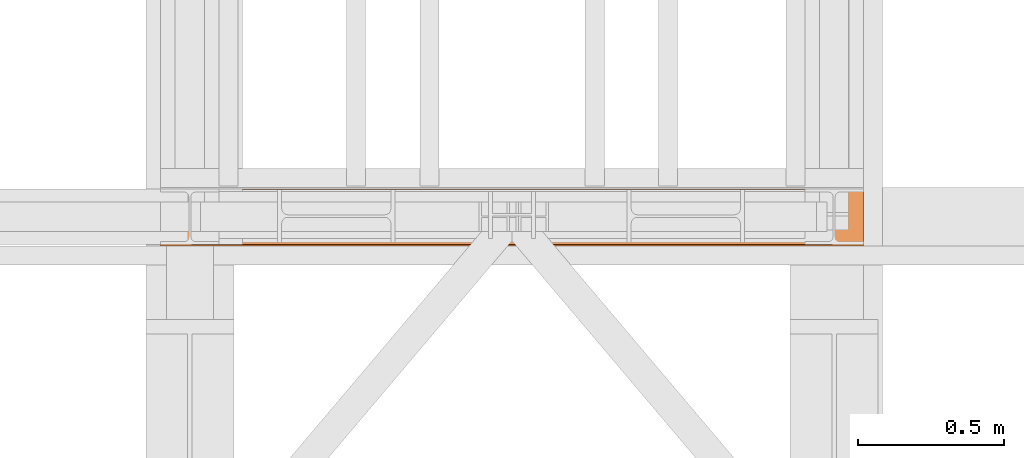
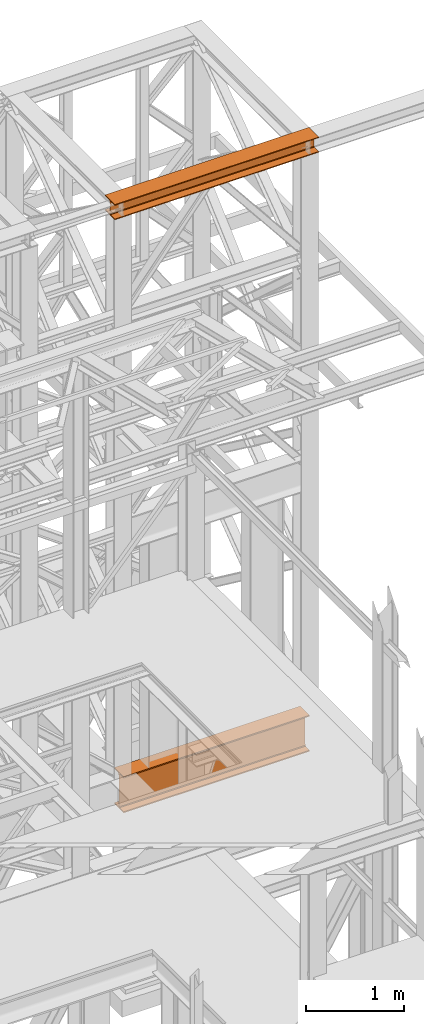
# One storey, part 176 of 208: 2 proxies.
"""IFC2X3 building model written with IfcOpenShell, lengths in millimetres."""

import ifcopenshell
import ifcopenshell.guid

model = None  # the IFC model being written
_history = None  # IfcOwnerHistory: only IFC2X3 demands one
_inside = {}  # id of a spatial element -> (the spatial element, [elements in it])
_under = {}  # id of a project, library or spatial element -> (it, [spatial elements below it])
_declared = {}  # id of a project -> (the project, [libraries it declares])
_typed = {}  # id of a type object -> (the type object, [elements of that type])
_made_of = {}  # id of a material, layer set ... -> (it, [elements and type objects made of it])


def new_model(schema):
    """Start an empty IFC model of exactly this schema.

    Asked for "IFC4X3", IfcOpenShell would pick the latest addendum, in which some entities
    have other attributes; the version numbers below select the first issue.
    IFC2X3 requires an IfcOwnerHistory on every rooted entity: one is made here for all.
    """
    global model, _history
    if schema == "IFC4X3":
        model = ifcopenshell.file(schema_version=(4, 3, 0, 0))
    else:
        model = ifcopenshell.file(schema=schema)
    _inside.clear()
    _under.clear()
    _declared.clear()
    _typed.clear()
    _made_of.clear()
    _history = None
    if model.schema == "IFC2X3":
        org = make("IfcOrganization", Name="unknown")
        user = make(
            "IfcPersonAndOrganization",
            ThePerson=make("IfcPerson", FamilyName="unknown"),
            TheOrganization=org,
        )
        app = make(
            "IfcApplication",
            ApplicationDeveloper=org,
            Version="unknown",
            ApplicationFullName="unknown",
            ApplicationIdentifier="unknown",
        )
        _history = make(
            "IfcOwnerHistory",
            OwningUser=user,
            OwningApplication=app,
            ChangeAction="ADDED",
            CreationDate=0,
        )
    return model


def make(cls, **values):
    """One entity of the class cls with the attributes given. An attribute that is None is left unset."""
    return model.create_entity(
        cls, **{name: value for name, value in values.items() if value is not None}
    )


def entity(cls, *values):
    """Any entity or typed value of the class cls, its attributes in the order of the schema. None: left unset."""
    e = model.create_entity(cls)
    for i, value in enumerate(values):
        if value is not None:
            e[i] = value
    return e


def rooted(cls, **values):
    """An entity with a GlobalId (a new one), such as an element, a storey or a relation."""
    return make(cls, GlobalId=ifcopenshell.guid.new(), OwnerHistory=_history, **values)


def si_unit(unit_type, name, prefix=None):
    """IfcSIUnit, for example si_unit("LENGTHUNIT", "METRE", prefix="MILLI")."""
    return make("IfcSIUnit", UnitType=unit_type, Prefix=prefix, Name=name)


def converted_unit(unit_type, name, factor, base, dimensions=None, offset=None):
    """IfcConversionBasedUnit, such as the inch: factor (a typed value) times the base unit."""
    return make(
        "IfcConversionBasedUnit"
        if offset is None
        else "IfcConversionBasedUnitWithOffset",
        ConversionOffset=offset,
        Dimensions=None
        if dimensions is None
        else entity("IfcDimensionalExponents", *dimensions),
        UnitType=unit_type,
        Name=name,
        ConversionFactor=make(
            "IfcMeasureWithUnit", ValueComponent=factor, UnitComponent=base
        ),
    )


def assignment(units):
    """IfcUnitAssignment: the units of a project."""
    return None if units is None else make("IfcUnitAssignment", Units=units)


def point(xyz):
    """IfcCartesianPoint."""
    return None if xyz is None else make("IfcCartesianPoint", Coordinates=xyz)


def direction(xyz):
    """IfcDirection."""
    return None if xyz is None else make("IfcDirection", DirectionRatios=xyz)


def frame(location, z_axis=None, x_axis=None):
    """IfcAxis2Placement3D, a coordinate frame: its origin and axes. An axis left out is left unset."""
    return make(
        "IfcAxis2Placement3D",
        Location=point(location),
        Axis=direction(z_axis),
        RefDirection=direction(x_axis),
    )


def origin():
    """The frame at (0, 0, 0) with its axes left unset."""
    return frame((0.0, 0.0, 0.0))


def origin_with_axes():
    """The frame at (0, 0, 0) with the z axis (0, 0, 1) and the x axis (1, 0, 0) written out."""
    return frame((0.0, 0.0, 0.0), z_axis=(0.0, 0.0, 1.0), x_axis=(1.0, 0.0, 0.0))


def place(relative_to, where):
    """IfcLocalPlacement: puts the frame where relative to a parent placement (None: the world)."""
    return make(
        "IfcLocalPlacement", PlacementRelTo=relative_to, RelativePlacement=where
    )


def context(
    kind, dimensions, precision=None, world=None, true_north=None, identifier=None
):
    """IfcGeometricRepresentationContext, for example the 3D "Model" context."""
    return make(
        "IfcGeometricRepresentationContext",
        ContextIdentifier=identifier,
        ContextType=kind,
        CoordinateSpaceDimension=dimensions,
        Precision=precision,
        WorldCoordinateSystem=world,
        TrueNorth=true_north,
    )


def subcontext(parent, identifier, kind, view, scale=None):
    """IfcGeometricRepresentationSubContext, for example "Body" below "Model"."""
    return make(
        "IfcGeometricRepresentationSubContext",
        ContextIdentifier=identifier,
        ContextType=kind,
        ParentContext=parent,
        TargetScale=scale,
        TargetView=view,
    )


def project(units=None, contexts=None):
    """IfcProject with its units and contexts."""
    return rooted(
        "IfcProject",
        Name="project",
        RepresentationContexts=contexts,
        UnitsInContext=assignment(units),
    )


def spatial(cls, under=None, at=None, **own):
    """A site, building, storey or space (cls), placed at a placement, below another one or the project."""
    s = rooted(cls, ObjectPlacement=at, **own)
    if under is not None:
        _under.setdefault(under.id(), (under, []))[1].append(s)
    return s


def faces_of(points, faces, orient=None, outer=None):
    """IfcFace entities. A face is a list of loops; a loop is a list of indices into points, from 0.

    orient and outer hold one flag for each loop. By default every Orientation is true, the
    first loop of a face is its IfcFaceOuterBound and the others are IfcFaceBound.
    """
    made = []
    for i, loops in enumerate(faces):
        bounds = []
        for j, loop in enumerate(loops):
            is_outer = j == 0 if outer is None else outer[i][j]
            bounds.append(
                make(
                    "IfcFaceOuterBound" if is_outer else "IfcFaceBound",
                    Bound=make("IfcPolyLoop", Polygon=[points[k] for k in loop]),
                    Orientation=True if orient is None else orient[i][j],
                )
            )
        made.append(make("IfcFace", Bounds=bounds))
    return made


def faceted_brep(points, faces, orient=None, outer=None, voids=None):
    """IfcFacetedBrep: a solid bounded by flat faces; with voids (closed shells), ...WithVoids."""
    shared = [point(p) for p in points]
    hull = make("IfcClosedShell", CfsFaces=faces_of(shared, faces, orient, outer))
    if voids is None:
        return make("IfcFacetedBrep", Outer=hull)
    return make(
        "IfcFacetedBrepWithVoids",
        Outer=hull,
        Voids=[
            make(cls, CfsFaces=faces_of(shared, fs, o, b)) for cls, fs, o, b in voids
        ],
    )


def shape(context_of_items, identifier, shape_type, items):
    """IfcShapeRepresentation: the items that make up one representation, for example the "Body"."""
    return make(
        "IfcShapeRepresentation",
        ContextOfItems=context_of_items,
        RepresentationIdentifier=identifier,
        RepresentationType=shape_type,
        Items=items,
    )


def made_of(thing, what):
    """Note that an element or type object is made of a material, layer set ...; save() writes the relation."""
    if what is not None:
        _made_of.setdefault(what.id(), (what, []))[1].append(thing)
    return thing


def element(
    cls,
    number,
    at=None,
    inside=None,
    cuts=None,
    type_object=None,
    material=None,
    context=None,
    identifier="Body",
    shape_type=None,
    held_by="IfcProductDefinitionShape",
    body=None,
    shapes=None,
    **own,
):
    """One element of the class cls, such as IfcWall. Its Tag is "e" and its number.

    at: its placement. inside: the storey or other place that contains it. cuts: it is an
    opening in that element (IfcRelVoidsElement). A single representation is given by context,
    identifier, shape_type and body (its items); several are given by shapes. held_by: the class
    of the entity that holds the representations. save() writes the other relations.
    """
    e = rooted(cls, Tag="e%d" % number, ObjectPlacement=at, **own)
    if body is not None:
        shapes = [shape(context, identifier, shape_type, body)]
    if shapes is not None:
        e.Representation = make(held_by, Representations=shapes)
    if inside is not None:
        _inside.setdefault(inside.id(), (inside, []))[1].append(e)
    if cuts is not None:
        rooted(
            "IfcRelVoidsElement", RelatingBuildingElement=cuts, RelatedOpeningElement=e
        )
    if type_object is not None:
        _typed.setdefault(type_object.id(), (type_object, []))[1].append(e)
    return made_of(e, material)


def aggregate(whole, parts):
    """IfcRelAggregates: a whole, such as a stair, and the parts it consists of."""
    return rooted("IfcRelAggregates", RelatingObject=whole, RelatedObjects=parts)


def save(model, path):
    """Write the relations noted so far, then the file.

    IfcRelAggregates (storeys below a building ...), IfcRelContainedInSpatialStructure (elements
    in a storey), IfcRelDefinesByType, IfcRelAssociatesMaterial and IfcRelDeclares: one each for
    every whole, place, type object, material and project.
    """
    for whole, parts in _under.values():
        aggregate(whole, parts)
    for where, things in _inside.values():
        rooted(
            "IfcRelContainedInSpatialStructure",
            RelatedElements=things,
            RelatingStructure=where,
        )
    for kind, things in _typed.values():
        rooted("IfcRelDefinesByType", RelatedObjects=things, RelatingType=kind)
    for what, things in _made_of.values():
        rooted("IfcRelAssociatesMaterial", RelatedObjects=things, RelatingMaterial=what)
    for by, libraries in _declared.values():
        rooted("IfcRelDeclares", RelatingContext=by, RelatedDefinitions=libraries)
    model.write(path)


model = new_model("IFC2X3")

# Units and contexts
model_context = context("Model", 3, precision=1e-05, world=origin())
plan_context = context("Plan", 3, precision=1e-05, world=origin())
body_context = subcontext(model_context, "Body", "Model", "MODEL_VIEW")
ifc_project = project(units=[si_unit("LENGTHUNIT", "METRE", prefix="MILLI"), converted_unit("PLANEANGLEUNIT", "DEGREE", entity("IfcPlaneAngleMeasure", 0.0174532925199433), si_unit("PLANEANGLEUNIT", "RADIAN"), dimensions=[0, 0, 0, 0, 0, 0, 0]), si_unit("AREAUNIT", "SQUARE_METRE"), si_unit("VOLUMEUNIT", "CUBIC_METRE")], contexts=[model_context, plan_context])

# Building, storey
building_placement = place(None, origin())
building = spatial("IfcBuilding", under=ifc_project, at=building_placement, CompositionType="COMPLEX")
storey_placement = place(building_placement, origin_with_axes())
storey = spatial("IfcBuildingStorey", under=building, at=storey_placement, Name="Geschoss", CompositionType="ELEMENT")

# Proxies
proxy_1_placement = place(storey_placement, frame((6599.254968580832, -16057.57439657637, 4834.989987483023), z_axis=(0.0, 0.0, 1.0), x_axis=(1.0, 0.0, 0.0)))
element("IfcBuildingElementProxy", 1, at=proxy_1_placement, inside=storey, context=body_context, shape_type="Brep", body=[
    faceted_brep([(2188.009999895692, 0.01000000000021828, 450.0100178813937), (2188.009999895692, 190.0100125169756, 450.0100178813937), (2188.009999895692, 190.0100125169756, 435.4100240564349), (2188.009999895692, 120.7100073045494, 435.4100091552737), (2188.009999895692, 109.841562265754, 433.2347078418734), (2188.009999895692, 101.8853126263621, 425.2784563398363), (2188.009999895692, 99.71000619068764, 414.4100113010409), (2188.009999895692, 99.71000619068764, 35.60999167919181), (2188.009999895692, 101.8853126263621, 24.74154664039634), (2188.009999895692, 109.841562265754, 16.78529513835929), (2188.009999895692, 120.7100073045494, 14.60999382495902), (2188.009999895692, 190.0100125169756, 14.60999382495902), (2188.009999895692, 190.0100125169756, 0.01000000000021828), (2188.009999895692, 0.01000000000021828, 0.01000000000021828), (2188.009999895692, 0.01000000000021828, 14.60999382495902), (2188.009999895692, 69.3100052124264, 14.60999382495902), (2188.009999895692, 80.17845025122188, 16.78529513835929), (2188.009999895692, 88.13469989061377, 24.74154664039634), (2188.009999895692, 90.3100063262882, 35.60999167919181), (2188.009999895692, 90.3100063262882, 414.4100113010409), (2188.009999895692, 88.13469989061377, 425.2784563398363), (2188.009999895692, 80.17845025122188, 433.2347078418734), (2188.009999895692, 69.3100052124264, 435.4100091552737), (2188.009999895692, 0.01000000000021828, 435.4100240564349), (2188.009999895692, 190.0100125169756, 450.0100178813937), (2188.009999895692, 0.01000000000021828, 450.0100178813937), (0.01000000000021828, 0.01000000000021828, 450.0100178813937), (0.01000000000021828, 190.0100125169756, 450.0100178813937), (2188.009999895692, 190.0100125169756, 435.4100240564349), (2188.009999895692, 190.0100125169756, 450.0100178813937), (0.01000000000021828, 190.0100125169756, 450.0100178813937), (0.01000000000021828, 190.0100125169756, 435.4100240564349), (2188.009999895692, 120.7100073045494, 435.4100091552737), (2188.009999895692, 190.0100125169756, 435.4100240564349), (0.01000000000021828, 190.0100125169756, 435.4100240564349), (0.01000000000021828, 120.7100073045494, 435.4100091552737), (2188.009999895692, 109.841562265754, 433.2347078418734), (2188.009999895692, 120.7100073045494, 435.4100091552737), (0.01000000000021828, 120.7100073045494, 435.4100091552737), (0.01000000000021828, 109.841562265754, 433.2347078418734), (2188.009999895692, 101.8853126263621, 425.2784563398363), (2188.009999895692, 109.841562265754, 433.2347078418734), (0.01000000000021828, 109.841562265754, 433.2347078418734), (0.01000000000021828, 101.8853126263621, 425.2784563398363), (2188.009999895692, 99.71000619068764, 414.4100113010409), (2188.009999895692, 101.8853126263621, 425.2784563398363), (0.01000000000021828, 101.8853126263621, 425.2784563398363), (0.01000000000021828, 99.71000619068764, 414.4100113010409), (2188.009999895692, 99.71000619068764, 35.60999167919181), (2188.009999895692, 99.71000619068764, 414.4100113010409), (0.01000000000021828, 99.71000619068764, 414.4100113010409), (0.01000000000021828, 99.71000619068764, 35.60999167919181), (2188.009999895692, 101.8853126263621, 24.74154664039634), (2188.009999895692, 99.71000619068764, 35.60999167919181), (0.01000000000021828, 99.71000619068764, 35.60999167919181), (0.01000000000021828, 101.8853126263621, 24.74154664039634), (2188.009999895692, 109.841562265754, 16.78529513835929), (2188.009999895692, 101.8853126263621, 24.74154664039634), (0.01000000000021828, 101.8853126263621, 24.74154664039634), (0.01000000000021828, 109.841562265754, 16.78529513835929), (2188.009999895692, 120.7100073045494, 14.60999382495902), (2188.009999895692, 109.841562265754, 16.78529513835929), (0.01000000000021828, 109.841562265754, 16.78529513835929), (0.01000000000021828, 120.7100073045494, 14.60999382495902), (2188.009999895692, 190.0100125169756, 14.60999382495902), (2188.009999895692, 120.7100073045494, 14.60999382495902), (0.01000000000021828, 120.7100073045494, 14.60999382495902), (0.01000000000021828, 190.0100125169756, 14.60999382495902), (2188.009999895692, 190.0100125169756, 0.01000000000021828), (2188.009999895692, 190.0100125169756, 14.60999382495902), (0.01000000000021828, 190.0100125169756, 14.60999382495902), (0.01000000000021828, 190.0100125169756, 0.01000000000021828), (2188.009999895692, 0.01000000000021828, 0.01000000000021828), (2188.009999895692, 190.0100125169756, 0.01000000000021828), (0.01000000000021828, 190.0100125169756, 0.01000000000021828), (0.01000000000021828, 0.01000000000021828, 0.01000000000021828), (2188.009999895692, 0.01000000000021828, 14.60999382495902), (2188.009999895692, 0.01000000000021828, 0.01000000000021828), (0.01000000000021828, 0.01000000000021828, 0.01000000000021828), (0.01000000000021828, 0.01000000000021828, 14.60999382495902), (2188.009999895692, 69.3100052124264, 14.60999382495902), (2188.009999895692, 0.01000000000021828, 14.60999382495902), (0.01000000000021828, 0.01000000000021828, 14.60999382495902), (0.01000000000021828, 69.3100052124264, 14.60999382495902), (2188.009999895692, 80.17845025122188, 16.78529513835929), (2188.009999895692, 69.3100052124264, 14.60999382495902), (0.01000000000021828, 69.3100052124264, 14.60999382495902), (0.01000000000021828, 80.17845025122188, 16.78529513835929), (2188.009999895692, 88.13469989061377, 24.74154664039634), (2188.009999895692, 80.17845025122188, 16.78529513835929), (0.01000000000021828, 80.17845025122188, 16.78529513835929), (0.01000000000021828, 88.13469989061377, 24.74154664039634), (2188.009999895692, 90.3100063262882, 35.60999167919181), (2188.009999895692, 88.13469989061377, 24.74154664039634), (0.01000000000021828, 88.13469989061377, 24.74154664039634), (0.01000000000021828, 90.3100063262882, 35.60999167919181), (2188.009999895692, 90.3100063262882, 414.4100113010409), (2188.009999895692, 90.3100063262882, 35.60999167919181), (0.01000000000021828, 90.3100063262882, 35.60999167919181), (0.01000000000021828, 90.3100063262882, 414.4100113010409), (2188.009999895692, 88.13469989061377, 425.2784563398363), (2188.009999895692, 90.3100063262882, 414.4100113010409), (0.01000000000021828, 90.3100063262882, 414.4100113010409), (0.01000000000021828, 88.13469989061377, 425.2784563398363), (2188.009999895692, 80.17845025122188, 433.2347078418734), (2188.009999895692, 88.13469989061377, 425.2784563398363), (0.01000000000021828, 88.13469989061377, 425.2784563398363), (0.01000000000021828, 80.17845025122188, 433.2347078418734), (2188.009999895692, 69.3100052124264, 435.4100091552737), (2188.009999895692, 80.17845025122188, 433.2347078418734), (0.01000000000021828, 80.17845025122188, 433.2347078418734), (0.01000000000021828, 69.3100052124264, 435.4100091552737), (2188.009999895692, 0.01000000000021828, 435.4100240564349), (2188.009999895692, 69.3100052124264, 435.4100091552737), (0.01000000000021828, 69.3100052124264, 435.4100091552737), (0.01000000000021828, 0.01000000000021828, 435.4100240564349), (2188.009999895692, 0.01000000000021828, 450.0100178813937), (2188.009999895692, 0.01000000000021828, 435.4100240564349), (0.01000000000021828, 0.01000000000021828, 435.4100240564349), (0.01000000000021828, 0.01000000000021828, 450.0100178813937), (0.01000000000021828, 0.01000000000021828, 450.0100178813937), (0.01000000000021828, 0.01000000000021828, 435.4100240564349), (0.01000000000021828, 69.3100052124264, 435.4100091552737), (0.01000000000021828, 80.17845025122188, 433.2347078418734), (0.01000000000021828, 88.13469989061377, 425.2784563398363), (0.01000000000021828, 90.3100063262882, 414.4100113010409), (0.01000000000021828, 90.3100063262882, 35.60999167919181), (0.01000000000021828, 88.13469989061377, 24.74154664039634), (0.01000000000021828, 80.17845025122188, 16.78529513835929), (0.01000000000021828, 69.3100052124264, 14.60999382495902), (0.01000000000021828, 0.01000000000021828, 14.60999382495902), (0.01000000000021828, 0.01000000000021828, 0.01000000000021828), (0.01000000000021828, 190.0100125169756, 0.01000000000021828), (0.01000000000021828, 190.0100125169756, 14.60999382495902), (0.01000000000021828, 120.7100073045494, 14.60999382495902), (0.01000000000021828, 109.841562265754, 16.78529513835929), (0.01000000000021828, 101.8853126263621, 24.74154664039634), (0.01000000000021828, 99.71000619068764, 35.60999167919181), (0.01000000000021828, 99.71000619068764, 414.4100113010409), (0.01000000000021828, 101.8853126263621, 425.2784563398363), (0.01000000000021828, 109.841562265754, 433.2347078418734), (0.01000000000021828, 120.7100073045494, 435.4100091552737), (0.01000000000021828, 190.0100125169756, 435.4100240564349), (0.01000000000021828, 190.0100125169756, 450.0100178813937)], [[[0, 1, 2, 3, 4, 5, 6, 7, 8, 9, 10, 11, 12, 13, 14, 15, 16, 17, 18, 19, 20, 21, 22, 23]], [[24, 25, 26, 27]], [[28, 29, 30, 31]], [[32, 33, 34, 35]], [[36, 37, 38, 39]], [[40, 41, 42, 43]], [[44, 45, 46, 47]], [[48, 49, 50, 51]], [[52, 53, 54, 55]], [[56, 57, 58, 59]], [[60, 61, 62, 63]], [[64, 65, 66, 67]], [[68, 69, 70, 71]], [[72, 73, 74, 75]], [[76, 77, 78, 79]], [[80, 81, 82, 83]], [[84, 85, 86, 87]], [[88, 89, 90, 91]], [[92, 93, 94, 95]], [[96, 97, 98, 99]], [[100, 101, 102, 103]], [[104, 105, 106, 107]], [[108, 109, 110, 111]], [[112, 113, 114, 115]], [[116, 117, 118, 119]], [[120, 121, 122, 123, 124, 125, 126, 127, 128, 129, 130, 131, 132, 133, 134, 135, 136, 137, 138, 139, 140, 141, 142, 143]]], orient=[[False], [False], [False], [False], [False], [False], [False], [False], [False], [False], [False], [False], [False], [False], [False], [False], [False], [False], [False], [False], [False], [False], [False], [False], [False], [False]]),
])
proxy_2_placement = place(storey_placement, frame((6493.254967038549, -16062.574391808, 12249.99005869381), z_axis=(0.0, 0.0, 1.0), x_axis=(1.0, 0.0, 0.0)))
element("IfcBuildingElementProxy", 2, at=proxy_2_placement, inside=storey, context=body_context, shape_type="Brep", body=[
    faceted_brep([(0.01000000000021828, 0.01000000000021828, 0.01000000000021828), (0.01000000000021828, 200.0100029802325, 0.01000000000021828), (0.01000000000021828, 200.0100029802325, 10.00999791383765), (0.01000000000021828, 121.2600035762789, 10.01000536441825), (0.01000000000021828, 111.9441915473344, 11.87455041170142), (0.01000000000021828, 105.1245498640838, 18.69419349193595), (0.01000000000021828, 103.2600015571716, 28.01000458955787), (0.01000000000021828, 103.2600015571716, 162.0100153779986), (0.01000000000021828, 105.1245498640838, 171.3258264756205), (0.01000000000021828, 111.9441915473344, 178.145469555855), (0.01000000000021828, 121.2600035762789, 180.0100146031382), (0.01000000000021828, 200.0100029802325, 180.0100146031382), (0.01000000000021828, 200.0100029802325, 190.0100125169756), (0.01000000000021828, 0.01000000000021828, 190.0100125169756), (0.01000000000021828, 0.01000000000021828, 180.0100146031382), (0.01000000000021828, 78.75999940395377, 180.0100146031382), (0.01000000000021828, 88.07581143289826, 178.145469555855), (0.01000000000021828, 94.89545311614893, 171.3258264756205), (0.01000000000021828, 96.76000142306111, 162.0100153779986), (0.01000000000021828, 96.76000142306111, 28.01000458955787), (0.01000000000021828, 94.89545311614893, 18.69419349193595), (0.01000000000021828, 88.07581143289826, 11.87455041170142), (0.01000000000021828, 78.75999940395377, 10.01000536441825), (0.01000000000021828, 0.01000000000021828, 10.00999791383765), (0.01000000000021828, 200.0100029802325, 0.01000000000021828), (0.01000000000021828, 0.01000000000021828, 0.01000000000021828), (2400.010002980234, 0.01000000000021828, 0.01000000000021828), (2400.010002980234, 200.0100029802325, 0.01000000000021828), (0.01000000000021828, 200.0100029802325, 10.00999791383765), (0.01000000000021828, 200.0100029802325, 0.01000000000021828), (2400.010002980234, 200.0100029802325, 0.01000000000021828), (2400.010002980234, 200.0100029802325, 10.00999791383765), (0.01000000000021828, 121.2600035762789, 10.01000536441825), (0.01000000000021828, 200.0100029802325, 10.00999791383765), (2400.010002980234, 200.0100029802325, 10.00999791383765), (2400.010002980234, 121.2600035762789, 10.01000536441825), (0.01000000000021828, 111.9441915473344, 11.87455041170142), (0.01000000000021828, 121.2600035762789, 10.01000536441825), (2400.010002980234, 121.2600035762789, 10.01000536441825), (2400.010002980234, 111.9441915473344, 11.87455041170142), (0.01000000000021828, 105.1245498640838, 18.69419349193595), (0.01000000000021828, 111.9441915473344, 11.87455041170142), (2400.010002980234, 111.9441915473344, 11.87455041170142), (2400.010002980234, 105.1245498640838, 18.69419349193595), (0.01000000000021828, 103.2600015571716, 28.01000458955787), (0.01000000000021828, 105.1245498640838, 18.69419349193595), (2400.010002980234, 105.1245498640838, 18.69419349193595), (2400.010002980234, 103.2600015571716, 28.01000458955787), (0.01000000000021828, 103.2600015571716, 162.0100153779986), (0.01000000000021828, 103.2600015571716, 28.01000458955787), (2400.010002980234, 103.2600015571716, 28.01000458955787), (2400.010002980234, 103.2600015571716, 162.0100153779986), (0.01000000000021828, 105.1245498640838, 171.3258264756205), (0.01000000000021828, 103.2600015571716, 162.0100153779986), (2400.010002980234, 103.2600015571716, 162.0100153779986), (2400.010002980234, 105.1245498640838, 171.3258264756205), (0.01000000000021828, 111.9441915473344, 178.145469555855), (0.01000000000021828, 105.1245498640838, 171.3258264756205), (2400.010002980234, 105.1245498640838, 171.3258264756205), (2400.010002980234, 111.9441915473344, 178.145469555855), (0.01000000000021828, 121.2600035762789, 180.0100146031382), (0.01000000000021828, 111.9441915473344, 178.145469555855), (2400.010002980234, 111.9441915473344, 178.145469555855), (2400.010002980234, 121.2600035762789, 180.0100146031382), (0.01000000000021828, 200.0100029802325, 180.0100146031382), (0.01000000000021828, 121.2600035762789, 180.0100146031382), (2400.010002980234, 121.2600035762789, 180.0100146031382), (2400.010002980234, 200.0100029802325, 180.0100146031382), (0.01000000000021828, 200.0100029802325, 190.0100125169756), (0.01000000000021828, 200.0100029802325, 180.0100146031382), (2400.010002980234, 200.0100029802325, 180.0100146031382), (2400.010002980234, 200.0100029802325, 190.0100125169756), (0.01000000000021828, 0.01000000000021828, 190.0100125169756), (0.01000000000021828, 200.0100029802325, 190.0100125169756), (2400.010002980234, 200.0100029802325, 190.0100125169756), (2400.010002980234, 0.01000000000021828, 190.0100125169756), (0.01000000000021828, 0.01000000000021828, 180.0100146031382), (0.01000000000021828, 0.01000000000021828, 190.0100125169756), (2400.010002980234, 0.01000000000021828, 190.0100125169756), (2400.010002980234, 0.01000000000021828, 180.0100146031382), (0.01000000000021828, 78.75999940395377, 180.0100146031382), (0.01000000000021828, 0.01000000000021828, 180.0100146031382), (2400.010002980234, 0.01000000000021828, 180.0100146031382), (2400.010002980234, 78.75999940395377, 180.0100146031382), (0.01000000000021828, 88.07581143289826, 178.145469555855), (0.01000000000021828, 78.75999940395377, 180.0100146031382), (2400.010002980234, 78.75999940395377, 180.0100146031382), (2400.010002980234, 88.07581143289826, 178.145469555855), (0.01000000000021828, 94.89545311614893, 171.3258264756205), (0.01000000000021828, 88.07581143289826, 178.145469555855), (2400.010002980234, 88.07581143289826, 178.145469555855), (2400.010002980234, 94.89545311614893, 171.3258264756205), (0.01000000000021828, 96.76000142306111, 162.0100153779986), (0.01000000000021828, 94.89545311614893, 171.3258264756205), (2400.010002980234, 94.89545311614893, 171.3258264756205), (2400.010002980234, 96.76000142306111, 162.0100153779986), (0.01000000000021828, 96.76000142306111, 28.01000458955787), (0.01000000000021828, 96.76000142306111, 162.0100153779986), (2400.010002980234, 96.76000142306111, 162.0100153779986), (2400.010002980234, 96.76000142306111, 28.01000458955787), (0.01000000000021828, 94.89545311614893, 18.69419349193595), (0.01000000000021828, 96.76000142306111, 28.01000458955787), (2400.010002980234, 96.76000142306111, 28.01000458955787), (2400.010002980234, 94.89545311614893, 18.69419349193595), (0.01000000000021828, 88.07581143289826, 11.87455041170142), (0.01000000000021828, 94.89545311614893, 18.69419349193595), (2400.010002980234, 94.89545311614893, 18.69419349193595), (2400.010002980234, 88.07581143289826, 11.87455041170142), (0.01000000000021828, 78.75999940395377, 10.01000536441825), (0.01000000000021828, 88.07581143289826, 11.87455041170142), (2400.010002980234, 88.07581143289826, 11.87455041170142), (2400.010002980234, 78.75999940395377, 10.01000536441825), (0.01000000000021828, 0.01000000000021828, 10.00999791383765), (0.01000000000021828, 78.75999940395377, 10.01000536441825), (2400.010002980234, 78.75999940395377, 10.01000536441825), (2400.010002980234, 0.01000000000021828, 10.00999791383765), (0.01000000000021828, 0.01000000000021828, 0.01000000000021828), (0.01000000000021828, 0.01000000000021828, 10.00999791383765), (2400.010002980234, 0.01000000000021828, 10.00999791383765), (2400.010002980234, 0.01000000000021828, 0.01000000000021828), (2400.010002980234, 0.01000000000021828, 0.01000000000021828), (2400.010002980234, 0.01000000000021828, 10.00999791383765), (2400.010002980234, 78.75999940395377, 10.01000536441825), (2400.010002980234, 88.07581143289826, 11.87455041170142), (2400.010002980234, 94.89545311614893, 18.69419349193595), (2400.010002980234, 96.76000142306111, 28.01000458955787), (2400.010002980234, 96.76000142306111, 162.0100153779986), (2400.010002980234, 94.89545311614893, 171.3258264756205), (2400.010002980234, 88.07581143289826, 178.145469555855), (2400.010002980234, 78.75999940395377, 180.0100146031382), (2400.010002980234, 0.01000000000021828, 180.0100146031382), (2400.010002980234, 0.01000000000021828, 190.0100125169756), (2400.010002980234, 200.0100029802325, 190.0100125169756), (2400.010002980234, 200.0100029802325, 180.0100146031382), (2400.010002980234, 121.2600035762789, 180.0100146031382), (2400.010002980234, 111.9441915473344, 178.145469555855), (2400.010002980234, 105.1245498640838, 171.3258264756205), (2400.010002980234, 103.2600015571716, 162.0100153779986), (2400.010002980234, 103.2600015571716, 28.01000458955787), (2400.010002980234, 105.1245498640838, 18.69419349193595), (2400.010002980234, 111.9441915473344, 11.87455041170142), (2400.010002980234, 121.2600035762789, 10.01000536441825), (2400.010002980234, 200.0100029802325, 10.00999791383765), (2400.010002980234, 200.0100029802325, 0.01000000000021828)], [[[0, 1, 2, 3, 4, 5, 6, 7, 8, 9, 10, 11, 12, 13, 14, 15, 16, 17, 18, 19, 20, 21, 22, 23]], [[24, 25, 26, 27]], [[28, 29, 30, 31]], [[32, 33, 34, 35]], [[36, 37, 38, 39]], [[40, 41, 42, 43]], [[44, 45, 46, 47]], [[48, 49, 50, 51]], [[52, 53, 54, 55]], [[56, 57, 58, 59]], [[60, 61, 62, 63]], [[64, 65, 66, 67]], [[68, 69, 70, 71]], [[72, 73, 74, 75]], [[76, 77, 78, 79]], [[80, 81, 82, 83]], [[84, 85, 86, 87]], [[88, 89, 90, 91]], [[92, 93, 94, 95]], [[96, 97, 98, 99]], [[100, 101, 102, 103]], [[104, 105, 106, 107]], [[108, 109, 110, 111]], [[112, 113, 114, 115]], [[116, 117, 118, 119]], [[120, 121, 122, 123, 124, 125, 126, 127, 128, 129, 130, 131, 132, 133, 134, 135, 136, 137, 138, 139, 140, 141, 142, 143]]], orient=[[False], [False], [False], [False], [False], [False], [False], [False], [False], [False], [False], [False], [False], [False], [False], [False], [False], [False], [False], [False], [False], [False], [False], [False], [False], [False]]),
])

save(model, "model.ifc")
